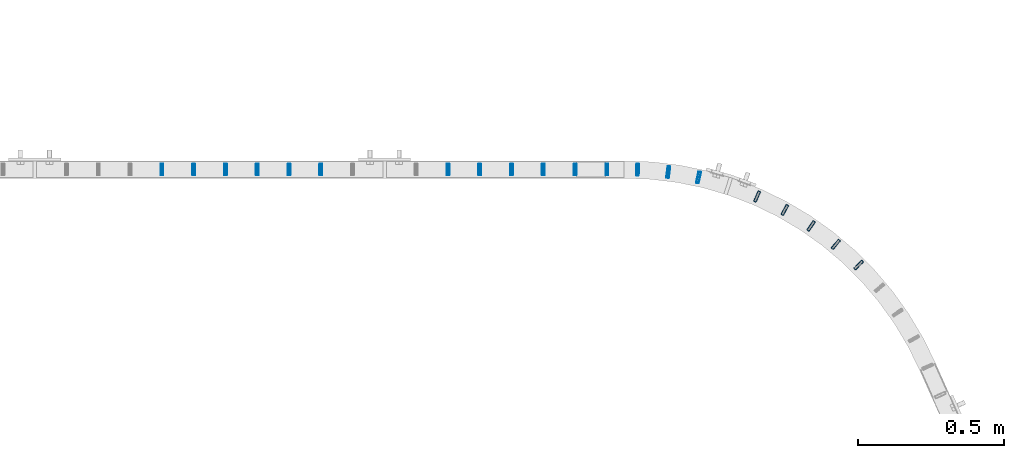
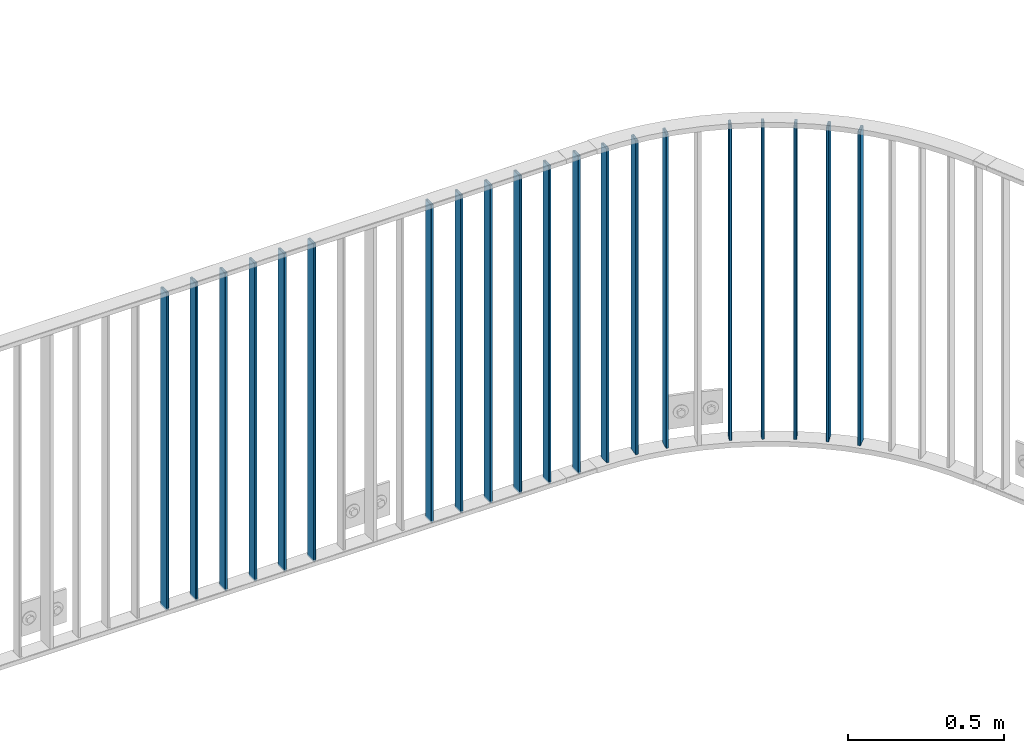
# One storey, part 17 of 156: 20 beams, 2 elements without a shape of their own.
"""IFC2X3 building model written with IfcOpenShell, lengths in millimetres."""

from ifc_helpers import new_model, si_unit, frame, origin_with_axes, origin_2d_with_axis, place, context, subcontext, project, spatial, hollow_rectangle, extrude, clip, halfspace, material, type_object, element, aggregate, save


model = new_model("IFC2X3")

# Units and contexts
model_context = context("Model", 3, precision=1e-05, world=origin_with_axes())
body_context = subcontext(model_context, "Body", "Model", "MODEL_VIEW")
ifc_project = project(units=[si_unit("LENGTHUNIT", "METRE", prefix="MILLI"), si_unit("AREAUNIT", "SQUARE_METRE"), si_unit("VOLUMEUNIT", "CUBIC_METRE"), si_unit("MASSUNIT", "GRAM", prefix="KILO"), si_unit("TIMEUNIT", "SECOND"), si_unit("PLANEANGLEUNIT", "RADIAN"), si_unit("SOLIDANGLEUNIT", "STERADIAN"), si_unit("THERMODYNAMICTEMPERATUREUNIT", "DEGREE_CELSIUS"), si_unit("LUMINOUSINTENSITYUNIT", "LUMEN")], contexts=[model_context])

# Site, building, storey
site_placement = place(None, origin_with_axes())
site = spatial("IfcSite", under=ifc_project, at=site_placement, CompositionType="ELEMENT")
building_placement = place(site_placement, origin_with_axes())
building = spatial("IfcBuilding", under=site, at=building_placement, Name="Undefined", CompositionType="ELEMENT")
storey_placement = place(building_placement, origin_with_axes())
storey = spatial("IfcBuildingStorey", under=building, at=storey_placement, Name="Undefined", CompositionType="ELEMENT", Elevation=0.0)

# Assembly, beams
assembly_1_placement = place(storey_placement, origin_with_axes())
assembly_1 = element("IfcElementAssembly", 1, at=assembly_1_placement, inside=storey, AssemblyPlace="NOTDEFINED", PredefinedType="RIGID_FRAME")
ifc_material = material(Name="STEEL/S235JR")
beam_type = type_object("IfcBeamType", Name="K40/10/1.5", PredefinedType="NOTDEFINED")
beam_1_placement = place(assembly_1_placement, frame((26627.5220799483, 10552.2581039527, 3980.00000000003), z_axis=(0.703907474074221, 0.710291678074894, 0.0), x_axis=(0.0, 0.0, -1.0)))
beam_1 = element("IfcBeam", 2, at=beam_1_placement, type_object=beam_type, material=ifc_material, ObjectType="K40/10/1.5", context=body_context, shape_type="SweptSolid", body=[
    extrude(hollow_rectangle(XDim=10.0, YDim=40.0, WallThickness=1.5, InnerFilletRadius=1.5, OuterFilletRadius=3.0, at=origin_2d_with_axis()), frame((1230.0, 0.0, 0.0), z_axis=(-1.0, 0.0, 0.0), x_axis=(0.0, -1.0, 0.0)), (0.0, 0.0, 1.0), 1230.0),
])
beam_2_placement = place(assembly_1_placement, frame((26549.0470876038, 10623.1405563708, 3980.00000000003), z_axis=(0.635287997677067, 0.772275313607435, 0.0), x_axis=(0.0, 0.0, -1.0)))
beam_2 = element("IfcBeam", 3, at=beam_2_placement, type_object=beam_type, material=ifc_material, ObjectType="K40/10/1.5", context=body_context, shape_type="SweptSolid", body=[
    extrude(hollow_rectangle(XDim=10.0, YDim=40.0, WallThickness=1.5, InnerFilletRadius=1.5, OuterFilletRadius=3.0, at=origin_2d_with_axis()), frame((1230.0, 0.0, 0.0), z_axis=(-1.0, 0.0, 0.0), x_axis=(0.0, -1.0, 0.0)), (0.0, 0.0, 1.0), 1230.0),
])
beam_3_placement = place(assembly_1_placement, frame((26464.2932745539, 10686.3675280638, 3980.00000000003), z_axis=(0.561236425159656, 0.827655529235448, 0.0), x_axis=(0.0, 0.0, -1.0)))
beam_3 = element("IfcBeam", 4, at=beam_3_placement, type_object=beam_type, material=ifc_material, ObjectType="K40/10/1.5", context=body_context, shape_type="SweptSolid", body=[
    extrude(hollow_rectangle(XDim=10.0, YDim=40.0, WallThickness=1.5, InnerFilletRadius=1.5, OuterFilletRadius=3.0, at=origin_2d_with_axis()), frame((1230.0, 0.0, 0.0), z_axis=(-1.0, 0.0, 0.0), x_axis=(0.0, -1.0, 0.0)), (0.0, 0.0, 1.0), 1230.0),
])
beam_4_placement = place(assembly_1_placement, frame((26374.0231994092, 10741.388646776, 3980.00000000003), z_axis=(0.482385943052518, 0.875958790095363, 0.0), x_axis=(0.0, 0.0, -1.0)))
beam_4 = element("IfcBeam", 5, at=beam_4_placement, type_object=beam_type, material=ifc_material, ObjectType="K40/10/1.5", context=body_context, shape_type="SweptSolid", body=[
    extrude(hollow_rectangle(XDim=10.0, YDim=40.0, WallThickness=1.5, InnerFilletRadius=1.5, OuterFilletRadius=3.0, at=origin_2d_with_axis()), frame((1230.0, 0.0, 0.0), z_axis=(-1.0, 0.0, 0.0), x_axis=(0.0, -1.0, 0.0)), (0.0, 0.0, 1.0), 1230.0),
])
beam_5_placement = place(assembly_1_placement, frame((26279.0162461269, 10787.7325936698, 3980.00000000003), z_axis=(0.399410769021371, 0.916772075049059, 0.0), x_axis=(0.0, 0.0, -1.0)))
beam_5 = element("IfcBeam", 6, at=beam_5_placement, type_object=beam_type, material=ifc_material, ObjectType="K40/10/1.5", context=body_context, shape_type="SweptSolid", body=[
    extrude(hollow_rectangle(XDim=10.0, YDim=40.0, WallThickness=1.5, InnerFilletRadius=1.5, OuterFilletRadius=3.0, at=origin_2d_with_axis()), frame((1230.0, 0.0, 0.0), z_axis=(-1.0, 0.0, 0.0), x_axis=(0.0, -1.0, 0.0)), (0.0, 0.0, 1.0), 1230.0),
])
beam_6_placement = place(assembly_1_placement, frame((26078.2635513947, 10852.8125191952, 3980.00000000003), z_axis=(0.223953502984099, 0.974599829930804, 0.0), x_axis=(0.0, 0.0, -1.0)))
beam_6 = element("IfcBeam", 7, at=beam_6_placement, type_object=beam_type, material=ifc_material, ObjectType="K40/10/1.5", context=body_context, shape_type="SweptSolid", body=[
    extrude(hollow_rectangle(XDim=10.0, YDim=40.0, WallThickness=1.5, InnerFilletRadius=1.5, OuterFilletRadius=3.0, at=origin_2d_with_axis()), frame((1230.0, 0.0, 0.0), z_axis=(-1.0, 0.0, 0.0), x_axis=(0.0, -1.0, 0.0)), (0.0, 0.0, 1.0), 1230.0),
])
beam_7_placement = place(assembly_1_placement, frame((25974.2898348454, 10871.0042441302, 3980.00000000003), z_axis=(0.132971675024637, 0.991119838183629, 0.0), x_axis=(0.0, 0.0, -1.0)))
beam_7 = element("IfcBeam", 8, at=beam_7_placement, type_object=beam_type, material=ifc_material, ObjectType="K40/10/1.5", context=body_context, shape_type="SweptSolid", body=[
    extrude(hollow_rectangle(XDim=10.0, YDim=40.0, WallThickness=1.5, InnerFilletRadius=1.5, OuterFilletRadius=3.0, at=origin_2d_with_axis()), frame((1230.0, 0.0, 0.0), z_axis=(-1.0, 0.0, 0.0), x_axis=(0.0, -1.0, 0.0)), (0.0, 0.0, 1.0), 1230.0),
])
beam_8_placement = place(assembly_1_placement, frame((25869.1392802899, 10879.4191267333, 3980.00000000003), z_axis=(0.0408528590199239, 0.999165173487296, 0.0), x_axis=(0.0, 0.0, -1.0)))
beam_8 = element("IfcBeam", 9, at=beam_8_placement, type_object=beam_type, material=ifc_material, ObjectType="K40/10/1.5", context=body_context, shape_type="SweptSolid", body=[
    extrude(hollow_rectangle(XDim=10.0, YDim=40.0, WallThickness=1.5, InnerFilletRadius=1.5, OuterFilletRadius=3.0, at=origin_2d_with_axis()), frame((1230.0, 0.0, 0.0), z_axis=(-1.0, 0.0, 0.0), x_axis=(0.0, -1.0, 0.0)), (0.0, 0.0, 1.0), 1230.0),
])
beam_9_placement = place(assembly_1_placement, frame((25763.629999999, 10879.9998088346, 3980.00000000003), z_axis=(0.0, 1.0, 0.0), x_axis=(0.0, 0.0, -1.0)))
beam_9 = element("IfcBeam", 10, at=beam_9_placement, type_object=beam_type, material=ifc_material, ObjectType="K40/10/1.5", context=body_context, shape_type="Clipping", body=[
    clip(clip(extrude(hollow_rectangle(XDim=10.0, YDim=40.0, WallThickness=1.5, InnerFilletRadius=1.5, OuterFilletRadius=3.0, at=origin_2d_with_axis()), frame((1237.00000000003, 0.0, 0.0), z_axis=(-1.0, 0.0, 0.0), x_axis=(0.0, -1.0, 0.0)), (0.0, 0.0, 1.0), 1244.0), halfspace(frame((1237.00000000003, 4.34248751949781, 47.3810900558092), z_axis=(1.0, 0.0, 0.0), x_axis=(0.0, -0.768354814194188, -0.640024124158313)), False)), halfspace(frame((-6.99999999997453, -4.34248751950508, 47.3810900558092), z_axis=(-1.0, 0.0, 0.0), x_axis=(0.0, 0.763991285051099, -0.645226562043109)), False)),
])
aggregate(assembly_1, [beam_1, beam_2, beam_3, beam_4, beam_5, beam_6, beam_7, beam_8, beam_9])

assembly_2_placement = place(storey_placement, origin_with_axes())
assembly_2 = element("IfcElementAssembly", 11, at=assembly_2_placement, inside=storey, AssemblyPlace="NOTDEFINED", PredefinedType="RIGID_FRAME")
beam_10_placement = place(assembly_2_placement, frame((25654.539999999, 10879.9998088346, 3980.00000000003), z_axis=(0.0, 1.0, 0.0), x_axis=(0.0, 0.0, -1.0)))
beam_10 = element("IfcBeam", 12, at=beam_10_placement, type_object=beam_type, material=ifc_material, ObjectType="K40/10/1.5", context=body_context, shape_type="Clipping", body=[
    clip(clip(extrude(hollow_rectangle(XDim=10.0, YDim=40.0, WallThickness=1.5, InnerFilletRadius=1.5, OuterFilletRadius=3.0, at=origin_2d_with_axis()), frame((1237.00000000003, 0.0, 0.0), z_axis=(-1.0, 0.0, 0.0), x_axis=(0.0, -1.0, 0.0)), (0.0, 0.0, 1.0), 1244.0), halfspace(frame((1237.00000000003, 4.34248751949781, 47.3810900558092), z_axis=(1.0, 0.0, 0.0), x_axis=(0.0, -0.768354814194188, -0.640024124158313)), False)), halfspace(frame((-6.99999999997453, -4.34248751950508, 47.3810900558092), z_axis=(-1.0, 0.0, 0.0), x_axis=(0.0, 0.766598961668776, -0.642126180721792)), False)),
])
beam_11_placement = place(assembly_2_placement, frame((25545.449999999, 10879.9998088346, 3980.00000000003), z_axis=(0.0, 1.0, 0.0), x_axis=(0.0, 0.0, -1.0)))
beam_11 = element("IfcBeam", 13, at=beam_11_placement, type_object=beam_type, material=ifc_material, ObjectType="K40/10/1.5", context=body_context, shape_type="Clipping", body=[
    clip(clip(extrude(hollow_rectangle(XDim=10.0, YDim=40.0, WallThickness=1.5, InnerFilletRadius=1.5, OuterFilletRadius=3.0, at=origin_2d_with_axis()), frame((1237.00000000003, 0.0, 0.0), z_axis=(-1.0, 0.0, 0.0), x_axis=(0.0, -1.0, 0.0)), (0.0, 0.0, 1.0), 1244.0), halfspace(frame((1237.00000000003, 4.34248751949781, 47.3810900558092), z_axis=(1.0, 0.0, 0.0), x_axis=(0.0, -0.768354814194188, -0.640024124158313)), False)), halfspace(frame((-6.99999999997453, -4.34248751950508, 47.3810900558092), z_axis=(-1.0, 0.0, 0.0), x_axis=(0.0, 0.766598961668776, -0.642126180721792)), False)),
])
beam_12_placement = place(assembly_2_placement, frame((25436.359999999, 10879.9998088346, 3980.00000000003), z_axis=(0.0, 1.0, 0.0), x_axis=(0.0, 0.0, -1.0)))
beam_12 = element("IfcBeam", 14, at=beam_12_placement, type_object=beam_type, material=ifc_material, ObjectType="K40/10/1.5", context=body_context, shape_type="Clipping", body=[
    clip(clip(extrude(hollow_rectangle(XDim=10.0, YDim=40.0, WallThickness=1.5, InnerFilletRadius=1.5, OuterFilletRadius=3.0, at=origin_2d_with_axis()), frame((1237.00000000003, 0.0, 0.0), z_axis=(-1.0, 0.0, 0.0), x_axis=(0.0, -1.0, 0.0)), (0.0, 0.0, 1.0), 1244.0), halfspace(frame((1237.00000000003, 4.34248751949781, 47.3810900558092), z_axis=(1.0, 0.0, 0.0), x_axis=(0.0, -0.768354814194188, -0.640024124158313)), False)), halfspace(frame((-6.99999999997453, -4.34248751950508, 47.3810900558092), z_axis=(-1.0, 0.0, 0.0), x_axis=(0.0, 0.766598961668776, -0.642126180721792)), False)),
])
beam_13_placement = place(assembly_2_placement, frame((25327.269999999, 10879.9998088346, 3980.00000000003), z_axis=(0.0, 1.0, 0.0), x_axis=(0.0, 0.0, -1.0)))
beam_13 = element("IfcBeam", 15, at=beam_13_placement, type_object=beam_type, material=ifc_material, ObjectType="K40/10/1.5", context=body_context, shape_type="Clipping", body=[
    clip(clip(extrude(hollow_rectangle(XDim=10.0, YDim=40.0, WallThickness=1.5, InnerFilletRadius=1.5, OuterFilletRadius=3.0, at=origin_2d_with_axis()), frame((1237.00000000003, 0.0, 0.0), z_axis=(-1.0, 0.0, 0.0), x_axis=(0.0, -1.0, 0.0)), (0.0, 0.0, 1.0), 1244.0), halfspace(frame((1237.00000000003, 4.34248751949781, 47.3810900558092), z_axis=(1.0, 0.0, 0.0), x_axis=(0.0, -0.768354814194188, -0.640024124158313)), False)), halfspace(frame((-6.99999999997453, -4.34248751950508, 47.3810900558092), z_axis=(-1.0, 0.0, 0.0), x_axis=(0.0, 0.766598961668776, -0.642126180721792)), False)),
])
beam_14_placement = place(assembly_2_placement, frame((25218.179999999, 10879.9998088346, 3980.00000000003), z_axis=(0.0, 1.0, 0.0), x_axis=(0.0, 0.0, -1.0)))
beam_14 = element("IfcBeam", 16, at=beam_14_placement, type_object=beam_type, material=ifc_material, ObjectType="K40/10/1.5", context=body_context, shape_type="Clipping", body=[
    clip(clip(extrude(hollow_rectangle(XDim=10.0, YDim=40.0, WallThickness=1.5, InnerFilletRadius=1.5, OuterFilletRadius=3.0, at=origin_2d_with_axis()), frame((1237.00000000003, 0.0, 0.0), z_axis=(-1.0, 0.0, 0.0), x_axis=(0.0, -1.0, 0.0)), (0.0, 0.0, 1.0), 1244.0), halfspace(frame((1237.00000000003, 4.34248751949781, 47.3810900558092), z_axis=(1.0, 0.0, 0.0), x_axis=(0.0, -0.768354814194188, -0.640024124158313)), False)), halfspace(frame((-6.99999999997453, -4.34248751950508, 47.3810900558092), z_axis=(-1.0, 0.0, 0.0), x_axis=(0.0, 0.766598961668776, -0.642126180721792)), False)),
])
beam_15_placement = place(assembly_2_placement, frame((24781.809999999, 10879.9998088346, 3980.00000000003), z_axis=(0.0, 1.0, 0.0), x_axis=(0.0, 0.0, -1.0)))
beam_15 = element("IfcBeam", 17, at=beam_15_placement, type_object=beam_type, material=ifc_material, ObjectType="K40/10/1.5", context=body_context, shape_type="Clipping", body=[
    clip(clip(extrude(hollow_rectangle(XDim=10.0, YDim=40.0, WallThickness=1.5, InnerFilletRadius=1.5, OuterFilletRadius=3.0, at=origin_2d_with_axis()), frame((1237.00000000003, 0.0, 0.0), z_axis=(-1.0, 0.0, 0.0), x_axis=(0.0, -1.0, 0.0)), (0.0, 0.0, 1.0), 1244.0), halfspace(frame((1237.00000000003, 4.34248751949781, 47.3810900558092), z_axis=(1.0, 0.0, 0.0), x_axis=(0.0, -0.768354814194188, -0.640024124158313)), False)), halfspace(frame((-6.99999999997453, -4.34248751950508, 47.3810900558092), z_axis=(-1.0, 0.0, 0.0), x_axis=(0.0, 0.766598961668776, -0.642126180721792)), False)),
])
beam_16_placement = place(assembly_2_placement, frame((24672.719999999, 10879.9998088346, 3980.00000000003), z_axis=(0.0, 1.0, 0.0), x_axis=(0.0, 0.0, -1.0)))
beam_16 = element("IfcBeam", 18, at=beam_16_placement, type_object=beam_type, material=ifc_material, ObjectType="K40/10/1.5", context=body_context, shape_type="Clipping", body=[
    clip(clip(extrude(hollow_rectangle(XDim=10.0, YDim=40.0, WallThickness=1.5, InnerFilletRadius=1.5, OuterFilletRadius=3.0, at=origin_2d_with_axis()), frame((1237.00000000003, 0.0, 0.0), z_axis=(-1.0, 0.0, 0.0), x_axis=(0.0, -1.0, 0.0)), (0.0, 0.0, 1.0), 1244.0), halfspace(frame((1237.00000000003, 4.34248751949781, 47.3810900558092), z_axis=(1.0, 0.0, 0.0), x_axis=(0.0, -0.768354814194188, -0.640024124158313)), False)), halfspace(frame((-6.99999999997453, -4.34248751950508, 47.3810900558092), z_axis=(-1.0, 0.0, 0.0), x_axis=(0.0, 0.766598961668776, -0.642126180721792)), False)),
])
beam_17_placement = place(assembly_2_placement, frame((24563.629999999, 10879.9998088346, 3980.00000000003), z_axis=(0.0, 1.0, 0.0), x_axis=(0.0, 0.0, -1.0)))
beam_17 = element("IfcBeam", 19, at=beam_17_placement, type_object=beam_type, material=ifc_material, ObjectType="K40/10/1.5", context=body_context, shape_type="Clipping", body=[
    clip(clip(extrude(hollow_rectangle(XDim=10.0, YDim=40.0, WallThickness=1.5, InnerFilletRadius=1.5, OuterFilletRadius=3.0, at=origin_2d_with_axis()), frame((1237.00000000003, 0.0, 0.0), z_axis=(-1.0, 0.0, 0.0), x_axis=(0.0, -1.0, 0.0)), (0.0, 0.0, 1.0), 1244.0), halfspace(frame((1237.00000000003, 4.34248751949781, 47.3810900558092), z_axis=(1.0, 0.0, 0.0), x_axis=(0.0, -0.768354814194188, -0.640024124158313)), False)), halfspace(frame((-6.99999999997453, -4.34248751950508, 47.3810900558092), z_axis=(-1.0, 0.0, 0.0), x_axis=(0.0, 0.766598961668776, -0.642126180721792)), False)),
])
beam_18_placement = place(assembly_2_placement, frame((24454.539999999, 10879.9998088346, 3980.00000000003), z_axis=(0.0, 1.0, 0.0), x_axis=(0.0, 0.0, -1.0)))
beam_18 = element("IfcBeam", 20, at=beam_18_placement, type_object=beam_type, material=ifc_material, ObjectType="K40/10/1.5", context=body_context, shape_type="Clipping", body=[
    clip(clip(extrude(hollow_rectangle(XDim=10.0, YDim=40.0, WallThickness=1.5, InnerFilletRadius=1.5, OuterFilletRadius=3.0, at=origin_2d_with_axis()), frame((1237.00000000003, 0.0, 0.0), z_axis=(-1.0, 0.0, 0.0), x_axis=(0.0, -1.0, 0.0)), (0.0, 0.0, 1.0), 1244.0), halfspace(frame((1237.00000000003, 4.34248751949781, 47.3810900558092), z_axis=(1.0, 0.0, 0.0), x_axis=(0.0, -0.768354814194188, -0.640024124158313)), False)), halfspace(frame((-6.99999999997453, -4.34248751950508, 47.3810900558092), z_axis=(-1.0, 0.0, 0.0), x_axis=(0.0, 0.766598961668776, -0.642126180721792)), False)),
])
beam_19_placement = place(assembly_2_placement, frame((24345.449999999, 10879.9998088346, 3980.00000000003), z_axis=(0.0, 1.0, 0.0), x_axis=(0.0, 0.0, -1.0)))
beam_19 = element("IfcBeam", 21, at=beam_19_placement, type_object=beam_type, material=ifc_material, ObjectType="K40/10/1.5", context=body_context, shape_type="Clipping", body=[
    clip(clip(extrude(hollow_rectangle(XDim=10.0, YDim=40.0, WallThickness=1.5, InnerFilletRadius=1.5, OuterFilletRadius=3.0, at=origin_2d_with_axis()), frame((1237.00000000003, 0.0, 0.0), z_axis=(-1.0, 0.0, 0.0), x_axis=(0.0, -1.0, 0.0)), (0.0, 0.0, 1.0), 1244.0), halfspace(frame((1237.00000000003, 4.34248751949781, 47.3810900558092), z_axis=(1.0, 0.0, 0.0), x_axis=(0.0, -0.768354814194188, -0.640024124158313)), False)), halfspace(frame((-6.99999999997453, -4.34248751950508, 47.3810900558092), z_axis=(-1.0, 0.0, 0.0), x_axis=(0.0, 0.766598961668776, -0.642126180721792)), False)),
])
beam_20_placement = place(assembly_2_placement, frame((24236.359999999, 10879.9998088346, 3980.00000000003), z_axis=(0.0, 1.0, 0.0), x_axis=(0.0, 0.0, -1.0)))
beam_20 = element("IfcBeam", 22, at=beam_20_placement, type_object=beam_type, material=ifc_material, ObjectType="K40/10/1.5", context=body_context, shape_type="Clipping", body=[
    clip(clip(extrude(hollow_rectangle(XDim=10.0, YDim=40.0, WallThickness=1.5, InnerFilletRadius=1.5, OuterFilletRadius=3.0, at=origin_2d_with_axis()), frame((1237.00000000003, 0.0, 0.0), z_axis=(-1.0, 0.0, 0.0), x_axis=(0.0, -1.0, 0.0)), (0.0, 0.0, 1.0), 1244.0), halfspace(frame((1237.00000000003, 4.34248751949781, 47.3810900558092), z_axis=(1.0, 0.0, 0.0), x_axis=(0.0, -0.768354814194188, -0.640024124158313)), False)), halfspace(frame((-6.99999999997453, -4.34248751950508, 47.3810900558092), z_axis=(-1.0, 0.0, 0.0), x_axis=(0.0, 0.766598961668776, -0.642126180721792)), False)),
])
aggregate(assembly_2, [beam_10, beam_11, beam_12, beam_13, beam_14, beam_15, beam_16, beam_17, beam_18, beam_19, beam_20])

save(model, "model.ifc")
